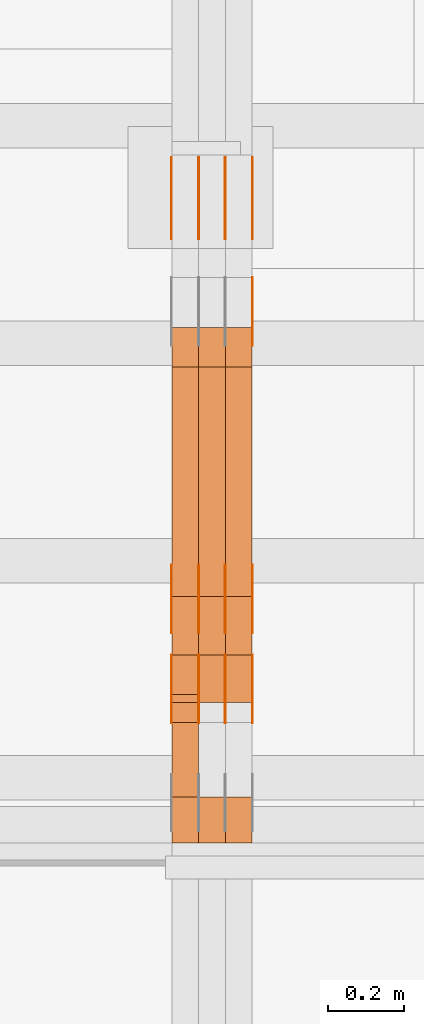
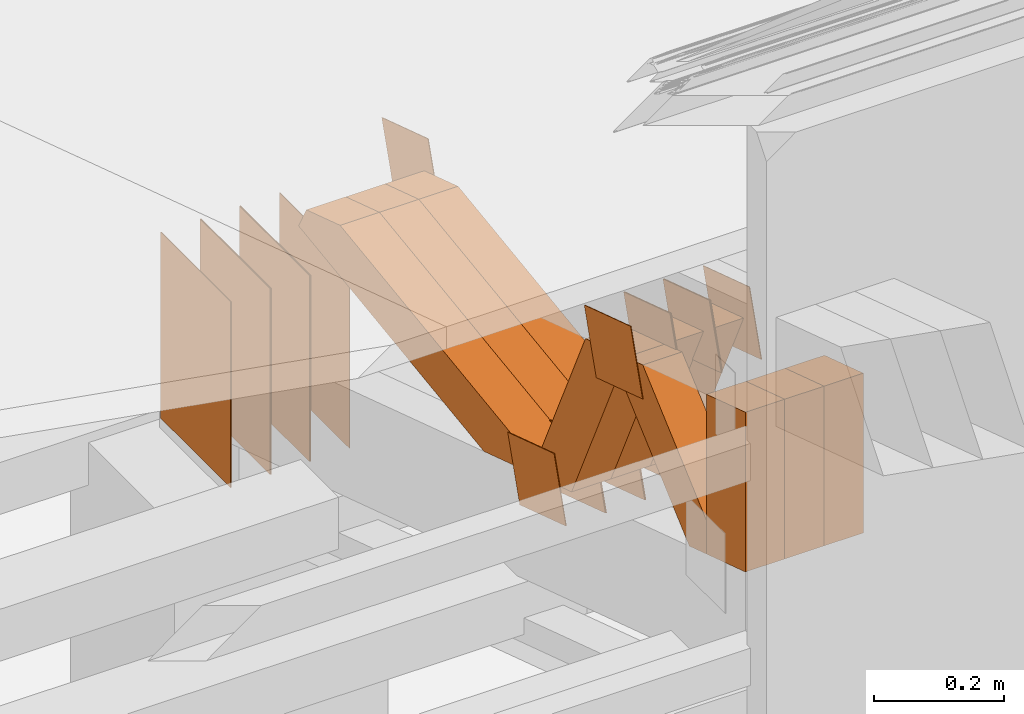
# One storey, part 88 of 385: 29 proxies.
"""IFC2X3 building model written with IfcOpenShell, lengths in millimetres."""

from ifc_helpers import new_model, entity, si_unit, converted_unit, derived_unit, direction, frame, origin, origin_2d_with_axis, place, context, subcontext, project, spatial, polyline, rectangle, outline, extrude, source, transform, mapped, material, type_object, type_shapes, element, save


model = new_model("IFC2X3")

# Units and contexts
model_context = context("Model", 3, precision=0.01, world=origin(), true_north=direction((6.12303176911189e-17, 1.0)))
body_context = subcontext(model_context, "Body", "Model", "MODEL_VIEW")
ifc_project = project(units=[si_unit("LENGTHUNIT", "METRE", prefix="MILLI"), si_unit("AREAUNIT", "SQUARE_METRE"), si_unit("VOLUMEUNIT", "CUBIC_METRE"), converted_unit("PLANEANGLEUNIT", "DEGREE", entity("IfcRatioMeasure", 0.0174532925199433), si_unit("PLANEANGLEUNIT", "RADIAN"), dimensions=[0, 0, 0, 0, 0, 0, 0]), si_unit("MASSUNIT", "GRAM", prefix="KILO"), derived_unit("MASSDENSITYUNIT", [(si_unit("MASSUNIT", "GRAM", prefix="KILO"), 1), (si_unit("LENGTHUNIT", "METRE"), -3)]), si_unit("TIMEUNIT", "SECOND"), si_unit("FREQUENCYUNIT", "HERTZ"), si_unit("THERMODYNAMICTEMPERATUREUNIT", "DEGREE_CELSIUS"), derived_unit("THERMALTRANSMITTANCEUNIT", [(si_unit("MASSUNIT", "GRAM", prefix="KILO"), 1), (si_unit("THERMODYNAMICTEMPERATUREUNIT", "KELVIN"), -1), (si_unit("TIMEUNIT", "SECOND"), -3)]), derived_unit("VOLUMETRICFLOWRATEUNIT", [(si_unit("LENGTHUNIT", "METRE"), 3), (si_unit("TIMEUNIT", "SECOND"), -1)]), si_unit("ELECTRICCURRENTUNIT", "AMPERE"), si_unit("ELECTRICVOLTAGEUNIT", "VOLT"), si_unit("POWERUNIT", "WATT"), si_unit("FORCEUNIT", "NEWTON", prefix="KILO"), si_unit("ILLUMINANCEUNIT", "LUX"), si_unit("LUMINOUSFLUXUNIT", "LUMEN"), si_unit("LUMINOUSINTENSITYUNIT", "CANDELA"), derived_unit("USERDEFINED", [(si_unit("MASSUNIT", "GRAM", prefix="KILO"), -1), (si_unit("LENGTHUNIT", "METRE"), -2), (si_unit("TIMEUNIT", "SECOND"), 3), (si_unit("LUMINOUSFLUXUNIT", "LUMEN"), 1)]), derived_unit("LINEARVELOCITYUNIT", [(si_unit("LENGTHUNIT", "METRE"), 1), (si_unit("TIMEUNIT", "SECOND"), -1)]), si_unit("PRESSUREUNIT", "PASCAL"), derived_unit("USERDEFINED", [(si_unit("LENGTHUNIT", "METRE"), -2), (si_unit("MASSUNIT", "GRAM", prefix="KILO"), 1), (si_unit("TIMEUNIT", "SECOND"), -2)])], contexts=[model_context])

# Site, building, storey
site_placement = place(None, origin())
site = spatial("IfcSite", under=ifc_project, at=site_placement, CompositionType="ELEMENT")
building_placement = place(site_placement, origin())
building = spatial("IfcBuilding", under=site, at=building_placement, CompositionType="ELEMENT")
storey_placement = place(building_placement, origin())
storey = spatial("IfcBuildingStorey", under=building, at=storey_placement, Name="Default", CompositionType="ELEMENT", Elevation=0.0)

# Proxies
ifc_material_1 = material(Name="IfcSurfaceStyle #101740")
building_element_proxy_type_1 = type_object("IfcBuildingElementProxyType", PredefinedType="NOTDEFINED", material=ifc_material_1)
shared_shape_1 = source(origin(), body_context, "Body", "SweptSolid", [
    extrude(outline(polyline([(-74.9998605591118, -59.9999264677601), (74.9998754286171, -59.9999264677601), (74.9998605591118, 59.9999264677602), (-74.9998754286171, 59.9999264677602), (-74.9998605591118, -59.9999264677601)])), frame((74.9998754286171, 60.0000503992849, 0.0), z_axis=(0.0, 0.0, 1.0), x_axis=(-1.0, 0.0, 0.0)), (0.0, 0.0, 1.0), 1.3),
])
type_shapes(building_element_proxy_type_1, [shared_shape_1])
proxy_1_placement = place(building_placement, frame((6386.29999999999, 16352.8320303235, 3323.23212676408), z_axis=(-1.0, 0.0, 0.0), x_axis=(0.0, -0.951056516295124, 0.309016994375039)))
element("IfcBuildingElementProxy", 1, at=proxy_1_placement, inside=storey, type_object=building_element_proxy_type_1, material=ifc_material_1, context=body_context, shape_type="MappedRepresentation", body=[
    mapped(shared_shape_1, transform((0.0, 0.0, 0.0), scale=1.0)),
])
ifc_material_2 = material(Name="IfcSurfaceStyle #101683")
building_element_proxy_type_2 = type_object("IfcBuildingElementProxyType", PredefinedType="NOTDEFINED", material=ifc_material_2)
shared_shape_2 = source(origin(), body_context, "Body", "SweptSolid", [
    extrude(outline(polyline([(-74.9998605591118, -59.9999264677601), (74.9998754286171, -59.9999264677601), (74.9998605591118, 59.9999264677602), (-74.9998754286171, 59.9999264677602), (-74.9998605591118, -59.9999264677601)])), frame((74.9998754286171, 60.0000503992849, 0.0), z_axis=(0.0, 0.0, 1.0), x_axis=(-1.0, 0.0, 0.0)), (0.0, 0.0, 1.0), 1.3),
])
type_shapes(building_element_proxy_type_2, [shared_shape_2])
proxy_2_placement = place(building_placement, frame((6315.0, 16352.8320303235, 3323.23212676408), z_axis=(-1.0, 0.0, 0.0), x_axis=(0.0, -0.951056516295124, 0.309016994375039)))
element("IfcBuildingElementProxy", 2, at=proxy_2_placement, inside=storey, type_object=building_element_proxy_type_2, material=ifc_material_2, context=body_context, shape_type="MappedRepresentation", body=[
    mapped(shared_shape_2, transform((0.0, 0.0, 0.0), scale=1.0)),
])
ifc_material_3 = material(Name="IfcSurfaceStyle #101626")
building_element_proxy_type_3 = type_object("IfcBuildingElementProxyType", PredefinedType="NOTDEFINED", material=ifc_material_3)
shared_shape_3 = source(origin(), body_context, "Body", "SweptSolid", [
    extrude(outline(polyline([(-74.9998605591118, -59.9999264677601), (74.9998754286171, -59.9999264677601), (74.9998605591118, 59.9999264677602), (-74.9998754286171, 59.9999264677602), (-74.9998605591118, -59.9999264677601)])), frame((74.9998754286171, 60.0000503992849, 0.0), z_axis=(0.0, 0.0, 1.0), x_axis=(-1.0, 0.0, 0.0)), (0.0, 0.0, 1.0), 1.3),
])
type_shapes(building_element_proxy_type_3, [shared_shape_3])
proxy_3_placement = place(building_placement, frame((6316.29999999999, 16352.8320303235, 3323.23212676408), z_axis=(-1.0, 0.0, 0.0), x_axis=(0.0, -0.951056516295124, 0.309016994375039)))
element("IfcBuildingElementProxy", 3, at=proxy_3_placement, inside=storey, type_object=building_element_proxy_type_3, material=ifc_material_3, context=body_context, shape_type="MappedRepresentation", body=[
    mapped(shared_shape_3, transform((0.0, 0.0, 0.0), scale=1.0)),
])
ifc_material_4 = material(Name="IfcSurfaceStyle #101569")
building_element_proxy_type_4 = type_object("IfcBuildingElementProxyType", PredefinedType="NOTDEFINED", material=ifc_material_4)
shared_shape_4 = source(origin(), body_context, "Body", "SweptSolid", [
    extrude(outline(polyline([(-74.9998605591118, -59.9999264677601), (74.9998754286171, -59.9999264677601), (74.9998605591118, 59.9999264677602), (-74.9998754286171, 59.9999264677602), (-74.9998605591118, -59.9999264677601)])), frame((74.9998754286171, 60.0000503992849, 0.0), z_axis=(0.0, 0.0, 1.0), x_axis=(-1.0, 0.0, 0.0)), (0.0, 0.0, 1.0), 1.29999999999999),
])
type_shapes(building_element_proxy_type_4, [shared_shape_4])
proxy_4_placement = place(building_placement, frame((6245.0, 16352.8320303235, 3323.23212676408), z_axis=(-1.0, 0.0, 0.0), x_axis=(0.0, -0.951056516295124, 0.309016994375039)))
element("IfcBuildingElementProxy", 4, at=proxy_4_placement, inside=storey, type_object=building_element_proxy_type_4, material=ifc_material_4, context=body_context, shape_type="MappedRepresentation", body=[
    mapped(shared_shape_4, transform((0.0, 0.0, 0.0), scale=1.0)),
])
ifc_material_5 = material(Name="IfcSurfaceStyle #101512")
building_element_proxy_type_5 = type_object("IfcBuildingElementProxyType", PredefinedType="NOTDEFINED", material=ifc_material_5)
shared_shape_5 = source(origin(), body_context, "Body", "SweptSolid", [
    extrude(outline(polyline([(-74.9998605591118, -59.9999264677601), (74.9998754286171, -59.9999264677601), (74.9998605591118, 59.9999264677602), (-74.9998754286171, 59.9999264677602), (-74.9998605591118, -59.9999264677601)])), frame((74.9998754286171, 60.0000503992849, 0.0), z_axis=(0.0, 0.0, 1.0), x_axis=(-1.0, 0.0, 0.0)), (0.0, 0.0, 1.0), 1.29999999999999),
])
type_shapes(building_element_proxy_type_5, [shared_shape_5])
proxy_5_placement = place(building_placement, frame((6246.29999999999, 16352.8320303235, 3323.23212676408), z_axis=(-1.0, 0.0, 0.0), x_axis=(0.0, -0.951056516295124, 0.309016994375039)))
element("IfcBuildingElementProxy", 5, at=proxy_5_placement, inside=storey, type_object=building_element_proxy_type_5, material=ifc_material_5, context=body_context, shape_type="MappedRepresentation", body=[
    mapped(shared_shape_5, transform((0.0, 0.0, 0.0), scale=1.0)),
])
ifc_material_6 = material(Name="IfcSurfaceStyle #101455")
building_element_proxy_type_6 = type_object("IfcBuildingElementProxyType", PredefinedType="NOTDEFINED", material=ifc_material_6)
shared_shape_6 = source(origin(), body_context, "Body", "SweptSolid", [
    extrude(outline(polyline([(-74.9998605591118, -59.9999264677601), (74.9998754286171, -59.9999264677601), (74.9998605591118, 59.9999264677602), (-74.9998754286171, 59.9999264677602), (-74.9998605591118, -59.9999264677601)])), frame((74.9998754286171, 60.0000503992849, 0.0), z_axis=(0.0, 0.0, 1.0), x_axis=(-1.0, 0.0, 0.0)), (0.0, 0.0, 1.0), 1.29999999999999),
])
type_shapes(building_element_proxy_type_6, [shared_shape_6])
proxy_6_placement = place(building_placement, frame((6175.0, 16352.8320303235, 3323.23212676408), z_axis=(-1.0, 0.0, 0.0), x_axis=(0.0, -0.951056516295124, 0.309016994375039)))
element("IfcBuildingElementProxy", 6, at=proxy_6_placement, inside=storey, type_object=building_element_proxy_type_6, material=ifc_material_6, context=body_context, shape_type="MappedRepresentation", body=[
    mapped(shared_shape_6, transform((0.0, 0.0, 0.0), scale=1.0)),
])
ifc_material_7 = material(Name="IfcSurfaceStyle #99346")
building_element_proxy_type_7 = type_object("IfcBuildingElementProxyType", PredefinedType="NOTDEFINED", material=ifc_material_7)
shared_shape_7 = source(origin(), body_context, "Body", "SweptSolid", [
    extrude(rectangle(XDim=350.0, YDim=215.999999999984, at=origin_2d_with_axis()), frame((175.0, 108.0, 0.0), z_axis=(0.0, 0.0, 1.0), x_axis=(-1.0, 0.0, 0.0)), (0.0, 0.0, 1.0), 1.29999999999999),
])
type_shapes(building_element_proxy_type_7, [shared_shape_7])
proxy_7_placement = place(building_placement, frame((6386.29999999999, 17459.2939453125, 3165.36425781251), z_axis=(-1.0, 0.0, 0.0), x_axis=(0.0, 0.0, -1.0)))
element("IfcBuildingElementProxy", 7, at=proxy_7_placement, inside=storey, type_object=building_element_proxy_type_7, material=ifc_material_7, context=body_context, shape_type="MappedRepresentation", body=[
    mapped(shared_shape_7, transform((0.0, 0.0, 0.0), scale=1.0)),
])
ifc_material_8 = material(Name="IfcSurfaceStyle #99289")
building_element_proxy_type_8 = type_object("IfcBuildingElementProxyType", PredefinedType="NOTDEFINED", material=ifc_material_8)
shared_shape_8 = source(origin(), body_context, "Body", "SweptSolid", [
    extrude(rectangle(XDim=350.0, YDim=215.999999999984, at=origin_2d_with_axis()), frame((175.0, 108.0, 0.0), z_axis=(0.0, 0.0, 1.0), x_axis=(-1.0, 0.0, 0.0)), (0.0, 0.0, 1.0), 1.29999999999999),
])
type_shapes(building_element_proxy_type_8, [shared_shape_8])
proxy_8_placement = place(building_placement, frame((6315.0, 17459.2939453125, 3165.36425781251), z_axis=(-1.0, 0.0, 0.0), x_axis=(0.0, 0.0, -1.0)))
element("IfcBuildingElementProxy", 8, at=proxy_8_placement, inside=storey, type_object=building_element_proxy_type_8, material=ifc_material_8, context=body_context, shape_type="MappedRepresentation", body=[
    mapped(shared_shape_8, transform((0.0, 0.0, 0.0), scale=1.0)),
])
ifc_material_9 = material(Name="IfcSurfaceStyle #99232")
building_element_proxy_type_9 = type_object("IfcBuildingElementProxyType", PredefinedType="NOTDEFINED", material=ifc_material_9)
shared_shape_9 = source(origin(), body_context, "Body", "SweptSolid", [
    extrude(rectangle(XDim=350.0, YDim=215.999999999984, at=origin_2d_with_axis()), frame((175.0, 108.0, 0.0), z_axis=(0.0, 0.0, 1.0), x_axis=(-1.0, 0.0, 0.0)), (0.0, 0.0, 1.0), 1.29999999999999),
])
type_shapes(building_element_proxy_type_9, [shared_shape_9])
proxy_9_placement = place(building_placement, frame((6316.29999999999, 17459.2939453125, 3165.36425781251), z_axis=(-1.0, 0.0, 0.0), x_axis=(0.0, 0.0, -1.0)))
element("IfcBuildingElementProxy", 9, at=proxy_9_placement, inside=storey, type_object=building_element_proxy_type_9, material=ifc_material_9, context=body_context, shape_type="MappedRepresentation", body=[
    mapped(shared_shape_9, transform((0.0, 0.0, 0.0), scale=1.0)),
])
ifc_material_10 = material(Name="IfcSurfaceStyle #99175")
building_element_proxy_type_10 = type_object("IfcBuildingElementProxyType", PredefinedType="NOTDEFINED", material=ifc_material_10)
shared_shape_10 = source(origin(), body_context, "Body", "SweptSolid", [
    extrude(rectangle(XDim=350.0, YDim=215.999999999984, at=origin_2d_with_axis()), frame((175.0, 108.0, 0.0), z_axis=(0.0, 0.0, 1.0), x_axis=(-1.0, 0.0, 0.0)), (0.0, 0.0, 1.0), 1.29999999999998),
])
type_shapes(building_element_proxy_type_10, [shared_shape_10])
proxy_10_placement = place(building_placement, frame((6245.0, 17459.2939453125, 3165.36425781251), z_axis=(-1.0, 0.0, 0.0), x_axis=(0.0, 0.0, -1.0)))
element("IfcBuildingElementProxy", 10, at=proxy_10_placement, inside=storey, type_object=building_element_proxy_type_10, material=ifc_material_10, context=body_context, shape_type="MappedRepresentation", body=[
    mapped(shared_shape_10, transform((0.0, 0.0, 0.0), scale=1.0)),
])
ifc_material_11 = material(Name="IfcSurfaceStyle #99118")
building_element_proxy_type_11 = type_object("IfcBuildingElementProxyType", PredefinedType="NOTDEFINED", material=ifc_material_11)
shared_shape_11 = source(origin(), body_context, "Body", "SweptSolid", [
    extrude(rectangle(XDim=350.0, YDim=215.999999999984, at=origin_2d_with_axis()), frame((175.0, 108.0, 0.0), z_axis=(0.0, 0.0, 1.0), x_axis=(-1.0, 0.0, 0.0)), (0.0, 0.0, 1.0), 1.29999999999998),
])
type_shapes(building_element_proxy_type_11, [shared_shape_11])
proxy_11_placement = place(building_placement, frame((6246.29999999999, 17459.2939453125, 3165.36425781251), z_axis=(-1.0, 0.0, 0.0), x_axis=(0.0, 0.0, -1.0)))
element("IfcBuildingElementProxy", 11, at=proxy_11_placement, inside=storey, type_object=building_element_proxy_type_11, material=ifc_material_11, context=body_context, shape_type="MappedRepresentation", body=[
    mapped(shared_shape_11, transform((0.0, 0.0, 0.0), scale=1.0)),
])
ifc_material_12 = material(Name="IfcSurfaceStyle #99061")
building_element_proxy_type_12 = type_object("IfcBuildingElementProxyType", PredefinedType="NOTDEFINED", material=ifc_material_12)
shared_shape_12 = source(origin(), body_context, "Body", "SweptSolid", [
    extrude(rectangle(XDim=350.0, YDim=215.999999999984, at=origin_2d_with_axis()), frame((175.0, 108.0, 0.0), z_axis=(0.0, 0.0, 1.0), x_axis=(-1.0, 0.0, 0.0)), (0.0, 0.0, 1.0), 1.29999999999998),
])
type_shapes(building_element_proxy_type_12, [shared_shape_12])
proxy_12_placement = place(building_placement, frame((6175.0, 17459.2939453125, 3165.36425781251), z_axis=(-1.0, 0.0, 0.0), x_axis=(0.0, 0.0, -1.0)))
element("IfcBuildingElementProxy", 12, at=proxy_12_placement, inside=storey, type_object=building_element_proxy_type_12, material=ifc_material_12, context=body_context, shape_type="MappedRepresentation", body=[
    mapped(shared_shape_12, transform((0.0, 0.0, 0.0), scale=1.0)),
])
ifc_material_13 = material(Name="IfcSurfaceStyle #97294")
building_element_proxy_type_13 = type_object("IfcBuildingElementProxyType", PredefinedType="NOTDEFINED", material=ifc_material_13)
shared_shape_13 = source(origin(), body_context, "Body", "SweptSolid", [
    extrude(outline(polyline([(-75.0003249421702, -60.0000773549573), (75.0003398116874, -60.0000773549573), (75.0003249421711, 60.0000773549573), (-75.0003398116883, 60.0000773549573), (-75.0003249421702, -60.0000773549573)])), frame((75.0003398116874, 60.0000773549573, 0.0), z_axis=(0.0, 0.0, 1.0), x_axis=(-1.0, 0.0, 0.0)), (0.0, 0.0, 1.0), 1.3),
])
type_shapes(building_element_proxy_type_13, [shared_shape_13])
proxy_13_placement = place(building_placement, frame((6386.29999999999, 16117.0849050545, 3705.49074668796), z_axis=(-1.0, 0.0, 0.0), x_axis=(0.0, -0.951056516295154, 0.309016994374948)))
element("IfcBuildingElementProxy", 13, at=proxy_13_placement, inside=storey, type_object=building_element_proxy_type_13, material=ifc_material_13, context=body_context, shape_type="MappedRepresentation", body=[
    mapped(shared_shape_13, transform((0.0, 0.0, 0.0), scale=1.0)),
])
ifc_material_14 = material(Name="IfcSurfaceStyle #97237")
building_element_proxy_type_14 = type_object("IfcBuildingElementProxyType", PredefinedType="NOTDEFINED", material=ifc_material_14)
shared_shape_14 = source(origin(), body_context, "Body", "SweptSolid", [
    extrude(outline(polyline([(-75.0003249421702, -60.0000773549573), (75.0003398116874, -60.0000773549573), (75.0003249421711, 60.0000773549573), (-75.0003398116883, 60.0000773549573), (-75.0003249421702, -60.0000773549573)])), frame((75.0003398116874, 60.0000773549573, 0.0), z_axis=(0.0, 0.0, 1.0), x_axis=(-1.0, 0.0, 0.0)), (0.0, 0.0, 1.0), 1.3),
])
type_shapes(building_element_proxy_type_14, [shared_shape_14])
proxy_14_placement = place(building_placement, frame((6315.0, 16117.0849050545, 3705.49074668796), z_axis=(-1.0, 0.0, 0.0), x_axis=(0.0, -0.951056516295154, 0.309016994374948)))
element("IfcBuildingElementProxy", 14, at=proxy_14_placement, inside=storey, type_object=building_element_proxy_type_14, material=ifc_material_14, context=body_context, shape_type="MappedRepresentation", body=[
    mapped(shared_shape_14, transform((0.0, 0.0, 0.0), scale=1.0)),
])
ifc_material_15 = material(Name="IfcSurfaceStyle #97180")
building_element_proxy_type_15 = type_object("IfcBuildingElementProxyType", PredefinedType="NOTDEFINED", material=ifc_material_15)
shared_shape_15 = source(origin(), body_context, "Body", "SweptSolid", [
    extrude(outline(polyline([(-75.0003249421702, -60.0000773549573), (75.0003398116874, -60.0000773549573), (75.0003249421711, 60.0000773549573), (-75.0003398116883, 60.0000773549573), (-75.0003249421702, -60.0000773549573)])), frame((75.0003398116874, 60.0000773549573, 0.0), z_axis=(0.0, 0.0, 1.0), x_axis=(-1.0, 0.0, 0.0)), (0.0, 0.0, 1.0), 1.3),
])
type_shapes(building_element_proxy_type_15, [shared_shape_15])
proxy_15_placement = place(building_placement, frame((6316.29999999999, 16117.0849050545, 3705.49074668796), z_axis=(-1.0, 0.0, 0.0), x_axis=(0.0, -0.951056516295154, 0.309016994374948)))
element("IfcBuildingElementProxy", 15, at=proxy_15_placement, inside=storey, type_object=building_element_proxy_type_15, material=ifc_material_15, context=body_context, shape_type="MappedRepresentation", body=[
    mapped(shared_shape_15, transform((0.0, 0.0, 0.0), scale=1.0)),
])
ifc_material_16 = material(Name="IfcSurfaceStyle #97123")
building_element_proxy_type_16 = type_object("IfcBuildingElementProxyType", PredefinedType="NOTDEFINED", material=ifc_material_16)
shared_shape_16 = source(origin(), body_context, "Body", "SweptSolid", [
    extrude(outline(polyline([(-75.0003249421702, -60.0000773549573), (75.0003398116874, -60.0000773549573), (75.0003249421711, 60.0000773549573), (-75.0003398116883, 60.0000773549573), (-75.0003249421702, -60.0000773549573)])), frame((75.0003398116874, 60.0000773549573, 0.0), z_axis=(0.0, 0.0, 1.0), x_axis=(-1.0, 0.0, 0.0)), (0.0, 0.0, 1.0), 1.29999999999999),
])
type_shapes(building_element_proxy_type_16, [shared_shape_16])
proxy_16_placement = place(building_placement, frame((6245.0, 16117.0849050545, 3705.49074668796), z_axis=(-1.0, 0.0, 0.0), x_axis=(0.0, -0.951056516295154, 0.309016994374948)))
element("IfcBuildingElementProxy", 16, at=proxy_16_placement, inside=storey, type_object=building_element_proxy_type_16, material=ifc_material_16, context=body_context, shape_type="MappedRepresentation", body=[
    mapped(shared_shape_16, transform((0.0, 0.0, 0.0), scale=1.0)),
])
ifc_material_17 = material(Name="IfcSurfaceStyle #97066")
building_element_proxy_type_17 = type_object("IfcBuildingElementProxyType", PredefinedType="NOTDEFINED", material=ifc_material_17)
shared_shape_17 = source(origin(), body_context, "Body", "SweptSolid", [
    extrude(outline(polyline([(-75.0003249421702, -60.0000773549573), (75.0003398116874, -60.0000773549573), (75.0003249421711, 60.0000773549573), (-75.0003398116883, 60.0000773549573), (-75.0003249421702, -60.0000773549573)])), frame((75.0003398116874, 60.0000773549573, 0.0), z_axis=(0.0, 0.0, 1.0), x_axis=(-1.0, 0.0, 0.0)), (0.0, 0.0, 1.0), 1.29999999999999),
])
type_shapes(building_element_proxy_type_17, [shared_shape_17])
proxy_17_placement = place(building_placement, frame((6246.29999999999, 16117.0849050545, 3705.49074668796), z_axis=(-1.0, 0.0, 0.0), x_axis=(0.0, -0.951056516295154, 0.309016994374948)))
element("IfcBuildingElementProxy", 17, at=proxy_17_placement, inside=storey, type_object=building_element_proxy_type_17, material=ifc_material_17, context=body_context, shape_type="MappedRepresentation", body=[
    mapped(shared_shape_17, transform((0.0, 0.0, 0.0), scale=1.0)),
])
ifc_material_18 = material(Name="IfcSurfaceStyle #97009")
building_element_proxy_type_18 = type_object("IfcBuildingElementProxyType", PredefinedType="NOTDEFINED", material=ifc_material_18)
shared_shape_18 = source(origin(), body_context, "Body", "SweptSolid", [
    extrude(outline(polyline([(-75.0003249421702, -60.0000773549573), (75.0003398116874, -60.0000773549573), (75.0003249421711, 60.0000773549573), (-75.0003398116883, 60.0000773549573), (-75.0003249421702, -60.0000773549573)])), frame((75.0003398116874, 60.0000773549573, 0.0), z_axis=(0.0, 0.0, 1.0), x_axis=(-1.0, 0.0, 0.0)), (0.0, 0.0, 1.0), 1.29999999999999),
])
type_shapes(building_element_proxy_type_18, [shared_shape_18])
proxy_18_placement = place(building_placement, frame((6175.0, 16117.0849050545, 3705.49074668796), z_axis=(-1.0, 0.0, 0.0), x_axis=(0.0, -0.951056516295154, 0.309016994374948)))
element("IfcBuildingElementProxy", 18, at=proxy_18_placement, inside=storey, type_object=building_element_proxy_type_18, material=ifc_material_18, context=body_context, shape_type="MappedRepresentation", body=[
    mapped(shared_shape_18, transform((0.0, 0.0, 0.0), scale=1.0)),
])
ifc_material_19 = material(Name="IfcSurfaceStyle #95926")
building_element_proxy_type_19 = type_object("IfcBuildingElementProxyType", PredefinedType="NOTDEFINED", material=ifc_material_19)
shared_shape_19 = source(origin(), body_context, "Body", "SweptSolid", [
    extrude(outline(polyline([(-74.9998605591058, -59.9999264677524), (74.999875428623, -59.9999264677524), (74.9998605591068, 59.9999264677524), (-74.9998754286239, 59.9999264677524), (-74.9998605591058, -59.9999264677524)])), frame((75.0002460484325, 60.0000016373508, 0.0), z_axis=(0.0, 0.0, 1.0), x_axis=(-1.0, 0.0, 0.0)), (0.0, 0.0, 1.0), 1.3),
])
type_shapes(building_element_proxy_type_19, [shared_shape_19])
proxy_19_placement = place(building_placement, frame((6386.29999999999, 17107.0599369346, 3383.82825001787), z_axis=(-1.0, 0.0, 0.0), x_axis=(0.0, -0.951056516295154, 0.309016994374948)))
element("IfcBuildingElementProxy", 19, at=proxy_19_placement, inside=storey, type_object=building_element_proxy_type_19, material=ifc_material_19, context=body_context, shape_type="MappedRepresentation", body=[
    mapped(shared_shape_19, transform((0.0, 0.0, 0.0), scale=1.0)),
])
ifc_material_20 = material(Name="IfcSurfaceStyle #87091")
building_element_proxy_type_20 = type_object("IfcBuildingElementProxyType", Name="T1-W50 87089", PredefinedType="NOTDEFINED", material=ifc_material_20)
shared_shape_20 = source(origin(), body_context, "Body", "SweptSolid", [
    extrude(outline(polyline([(-128.56619634284, -47.4999385885712), (133.151257249084, -47.4999385885712), (161.172800006526, -0.000129729183733609), (147.291467726413, 47.500068317755), (-142.513973767368, 47.500068317755), (-170.535354871815, -0.000129729183754689), (-128.56619634284, -47.4999385885712)])), frame((161.17310141218, 47.5001898716564, 0.0), z_axis=(0.0, 0.0, 1.0), x_axis=(-1.0, 0.0, 0.0)), (0.0, 0.0, 1.0), 70.0),
])
type_shapes(building_element_proxy_type_20, [shared_shape_20])
proxy_20_placement = place(building_placement, frame((6245.0, 16060.0297689714, 3761.73994820667), z_axis=(-1.0, 0.0, 0.0), x_axis=(0.0, -0.749388407538668, -0.662130662820156)))
element("IfcBuildingElementProxy", 20, at=proxy_20_placement, inside=storey, type_object=building_element_proxy_type_20, material=ifc_material_20, Name="T1-W50", context=body_context, shape_type="MappedRepresentation", body=[
    mapped(shared_shape_20, transform((0.0, 0.0, 0.0), scale=1.0)),
])
ifc_material_21 = material(Name="IfcSurfaceStyle #86845")
building_element_proxy_type_21 = type_object("IfcBuildingElementProxyType", Name="T1-W2 86843", PredefinedType="NOTDEFINED", material=ifc_material_21)
shared_shape_21 = source(origin(), body_context, "Body", "SweptSolid", [
    extrude(outline(polyline([(-130.705993652344, -60.0), (169.696350097656, -60.0), (130.706115722656, 60.0), (-169.696472167969, 60.0), (-130.705993652344, -60.0)])), frame((169.696429629256, 60.0, 0.0), z_axis=(0.0, 0.0, 1.0), x_axis=(-1.0, 0.0, 0.0)), (0.0, 0.0, 1.0), 70.0),
])
type_shapes(building_element_proxy_type_21, [shared_shape_21])
proxy_21_placement = place(building_placement, frame((6385.0, 15660.0, 3577.70158062465), z_axis=(-1.0, 0.0, 0.0), x_axis=(0.0, 0.0, 1.0)))
element("IfcBuildingElementProxy", 21, at=proxy_21_placement, inside=storey, type_object=building_element_proxy_type_21, material=ifc_material_21, Name="T1-W2", context=body_context, shape_type="MappedRepresentation", body=[
    mapped(shared_shape_21, transform((0.0, 0.0, 0.0), scale=1.0)),
])
ifc_material_22 = material(Name="IfcSurfaceStyle #86788")
building_element_proxy_type_22 = type_object("IfcBuildingElementProxyType", Name="T1-W2 86786", PredefinedType="NOTDEFINED", material=ifc_material_22)
shared_shape_22 = source(origin(), body_context, "Body", "SweptSolid", [
    extrude(outline(polyline([(-130.705993652344, -60.0), (169.696350097656, -60.0), (130.706115722656, 60.0), (-169.696472167969, 60.0), (-130.705993652344, -60.0)])), frame((169.696429629256, 60.0, 0.0), z_axis=(0.0, 0.0, 1.0), x_axis=(-1.0, 0.0, 0.0)), (0.0, 0.0, 1.0), 70.0),
])
type_shapes(building_element_proxy_type_22, [shared_shape_22])
proxy_22_placement = place(building_placement, frame((6315.0, 15660.0, 3577.70158062465), z_axis=(-1.0, 0.0, 0.0), x_axis=(0.0, 0.0, 1.0)))
element("IfcBuildingElementProxy", 22, at=proxy_22_placement, inside=storey, type_object=building_element_proxy_type_22, material=ifc_material_22, Name="T1-W2", context=body_context, shape_type="MappedRepresentation", body=[
    mapped(shared_shape_22, transform((0.0, 0.0, 0.0), scale=1.0)),
])
ifc_material_23 = material(Name="IfcSurfaceStyle #86731")
building_element_proxy_type_23 = type_object("IfcBuildingElementProxyType", Name="T1-W2 86729", PredefinedType="NOTDEFINED", material=ifc_material_23)
shared_shape_23 = source(origin(), body_context, "Body", "SweptSolid", [
    extrude(outline(polyline([(-130.705993652344, -60.0), (169.696350097656, -60.0), (130.706115722656, 60.0), (-169.696472167969, 60.0), (-130.705993652344, -60.0)])), frame((169.696429629256, 60.0, 0.0), z_axis=(0.0, 0.0, 1.0), x_axis=(-1.0, 0.0, 0.0)), (0.0, 0.0, 1.0), 70.0),
])
type_shapes(building_element_proxy_type_23, [shared_shape_23])
proxy_23_placement = place(building_placement, frame((6245.0, 15660.0, 3577.70158062465), z_axis=(-1.0, 0.0, 0.0), x_axis=(0.0, 0.0, 1.0)))
element("IfcBuildingElementProxy", 23, at=proxy_23_placement, inside=storey, type_object=building_element_proxy_type_23, material=ifc_material_23, Name="T1-W2", context=body_context, shape_type="MappedRepresentation", body=[
    mapped(shared_shape_23, transform((0.0, 0.0, 0.0), scale=1.0)),
])
ifc_material_24 = material(Name="IfcSurfaceStyle #86674")
building_element_proxy_type_24 = type_object("IfcBuildingElementProxyType", Name="T1-W44 86672", PredefinedType="NOTDEFINED", material=ifc_material_24)
shared_shape_24 = source(origin(), body_context, "Body", "SweptSolid", [
    extrude(outline(polyline([(-184.551057772692, -47.4997984945814), (177.527112951531, -47.4997984945814), (162.630077773546, -0.000452497529500495), (118.068221667048, 47.5000247433462), (-273.674354619433, 47.5000247433462), (-184.551057772692, -47.4997984945814)])), frame((177.527112951531, 47.5002721629815, 0.0), z_axis=(0.0, 0.0, 1.0), x_axis=(-1.0, 0.0, 0.0)), (0.0, 0.0, 1.0), 70.0),
])
type_shapes(building_element_proxy_type_24, [shared_shape_24])
proxy_24_placement = place(building_placement, frame((6385.0, 16220.4899216004, 3388.98238154171), z_axis=(-1.0, 0.0, 0.0), x_axis=(0.0, -0.425335045192995, 0.905035965766374)))
element("IfcBuildingElementProxy", 24, at=proxy_24_placement, inside=storey, type_object=building_element_proxy_type_24, material=ifc_material_24, Name="T1-W44", context=body_context, shape_type="MappedRepresentation", body=[
    mapped(shared_shape_24, transform((0.0, 0.0, 0.0), scale=1.0)),
])
ifc_material_25 = material(Name="IfcSurfaceStyle #86608")
building_element_proxy_type_25 = type_object("IfcBuildingElementProxyType", Name="T1-W44 86606", PredefinedType="NOTDEFINED", material=ifc_material_25)
shared_shape_25 = source(origin(), body_context, "Body", "SweptSolid", [
    extrude(outline(polyline([(-184.551057772692, -47.4997984945814), (177.527112951531, -47.4997984945814), (162.630077773546, -0.000452497529500495), (118.068221667048, 47.5000247433462), (-273.674354619433, 47.5000247433462), (-184.551057772692, -47.4997984945814)])), frame((177.527112951531, 47.5002721629815, 0.0), z_axis=(0.0, 0.0, 1.0), x_axis=(-1.0, 0.0, 0.0)), (0.0, 0.0, 1.0), 70.0),
])
type_shapes(building_element_proxy_type_25, [shared_shape_25])
proxy_25_placement = place(building_placement, frame((6315.0, 16220.4899216004, 3388.98238154171), z_axis=(-1.0, 0.0, 0.0), x_axis=(0.0, -0.425335045192995, 0.905035965766374)))
element("IfcBuildingElementProxy", 25, at=proxy_25_placement, inside=storey, type_object=building_element_proxy_type_25, material=ifc_material_25, Name="T1-W44", context=body_context, shape_type="MappedRepresentation", body=[
    mapped(shared_shape_25, transform((0.0, 0.0, 0.0), scale=1.0)),
])
ifc_material_26 = material(Name="IfcSurfaceStyle #86542")
building_element_proxy_type_26 = type_object("IfcBuildingElementProxyType", Name="T1-W44 86540", PredefinedType="NOTDEFINED", material=ifc_material_26)
shared_shape_26 = source(origin(), body_context, "Body", "SweptSolid", [
    extrude(outline(polyline([(-184.551057772692, -47.4997984945814), (177.527112951531, -47.4997984945814), (162.630077773546, -0.000452497529500495), (118.068221667048, 47.5000247433462), (-273.674354619433, 47.5000247433462), (-184.551057772692, -47.4997984945814)])), frame((177.527112951531, 47.5002721629815, 0.0), z_axis=(0.0, 0.0, 1.0), x_axis=(-1.0, 0.0, 0.0)), (0.0, 0.0, 1.0), 70.0),
])
type_shapes(building_element_proxy_type_26, [shared_shape_26])
proxy_26_placement = place(building_placement, frame((6245.0, 16220.4899216004, 3388.98238154171), z_axis=(-1.0, 0.0, 0.0), x_axis=(0.0, -0.425335045192995, 0.905035965766374)))
element("IfcBuildingElementProxy", 26, at=proxy_26_placement, inside=storey, type_object=building_element_proxy_type_26, material=ifc_material_26, Name="T1-W44", context=body_context, shape_type="MappedRepresentation", body=[
    mapped(shared_shape_26, transform((0.0, 0.0, 0.0), scale=1.0)),
])
ifc_material_27 = material(Name="IfcSurfaceStyle #86278")
building_element_proxy_type_27 = type_object("IfcBuildingElementProxyType", Name="T1-W8 86276", PredefinedType="NOTDEFINED", material=ifc_material_27)
shared_shape_27 = source(origin(), body_context, "Body", "SweptSolid", [
    extrude(outline(polyline([(-476.725263324644, -47.5001051695965), (180.672765845439, -47.5001051695965), (279.11020091716, -1.03605560390907e-06), (296.793624402619, 47.5001056876243), (-279.851327840575, 47.5001056876243), (-476.725263324644, -47.5001051695965)])), frame((296.793624402619, 47.5001056876243, 0.0), z_axis=(0.0, 0.0, 1.0), x_axis=(-1.0, 0.0, 0.0)), (0.0, 0.0, 1.0), 70.0),
])
type_shapes(building_element_proxy_type_27, [shared_shape_27])
proxy_27_placement = place(building_placement, frame((6385.0, 17036.40625, 3432.97192382813), z_axis=(-1.0, 0.0, 0.0), x_axis=(0.0, -0.990844046556832, -0.135011389900564)))
element("IfcBuildingElementProxy", 27, at=proxy_27_placement, inside=storey, type_object=building_element_proxy_type_27, material=ifc_material_27, Name="T1-W8", context=body_context, shape_type="MappedRepresentation", body=[
    mapped(shared_shape_27, transform((0.0, 0.0, 0.0), scale=1.0)),
])
ifc_material_28 = material(Name="IfcSurfaceStyle #86212")
building_element_proxy_type_28 = type_object("IfcBuildingElementProxyType", Name="T1-W8 86210", PredefinedType="NOTDEFINED", material=ifc_material_28)
shared_shape_28 = source(origin(), body_context, "Body", "SweptSolid", [
    extrude(outline(polyline([(-476.725263324644, -47.5001051695965), (180.672765845439, -47.5001051695965), (279.11020091716, -1.03605560390907e-06), (296.793624402619, 47.5001056876243), (-279.851327840575, 47.5001056876243), (-476.725263324644, -47.5001051695965)])), frame((296.793624402619, 47.5001056876243, 0.0), z_axis=(0.0, 0.0, 1.0), x_axis=(-1.0, 0.0, 0.0)), (0.0, 0.0, 1.0), 70.0),
])
type_shapes(building_element_proxy_type_28, [shared_shape_28])
proxy_28_placement = place(building_placement, frame((6315.0, 17036.40625, 3432.97192382813), z_axis=(-1.0, 0.0, 0.0), x_axis=(0.0, -0.990844046556832, -0.135011389900564)))
element("IfcBuildingElementProxy", 28, at=proxy_28_placement, inside=storey, type_object=building_element_proxy_type_28, material=ifc_material_28, Name="T1-W8", context=body_context, shape_type="MappedRepresentation", body=[
    mapped(shared_shape_28, transform((0.0, 0.0, 0.0), scale=1.0)),
])
ifc_material_29 = material(Name="IfcSurfaceStyle #86146")
building_element_proxy_type_29 = type_object("IfcBuildingElementProxyType", Name="T1-W8 86144", PredefinedType="NOTDEFINED", material=ifc_material_29)
shared_shape_29 = source(origin(), body_context, "Body", "SweptSolid", [
    extrude(outline(polyline([(-476.725263324644, -47.5001051695965), (180.672765845439, -47.5001051695965), (279.11020091716, -1.03605560390907e-06), (296.793624402619, 47.5001056876243), (-279.851327840575, 47.5001056876243), (-476.725263324644, -47.5001051695965)])), frame((296.793624402619, 47.5001056876243, 0.0), z_axis=(0.0, 0.0, 1.0), x_axis=(-1.0, 0.0, 0.0)), (0.0, 0.0, 1.0), 70.0),
])
type_shapes(building_element_proxy_type_29, [shared_shape_29])
proxy_29_placement = place(building_placement, frame((6245.0, 17036.40625, 3432.97192382813), z_axis=(-1.0, 0.0, 0.0), x_axis=(0.0, -0.990844046556832, -0.135011389900564)))
element("IfcBuildingElementProxy", 29, at=proxy_29_placement, inside=storey, type_object=building_element_proxy_type_29, material=ifc_material_29, Name="T1-W8", context=body_context, shape_type="MappedRepresentation", body=[
    mapped(shared_shape_29, transform((0.0, 0.0, 0.0), scale=1.0)),
])

save(model, "model.ifc")
